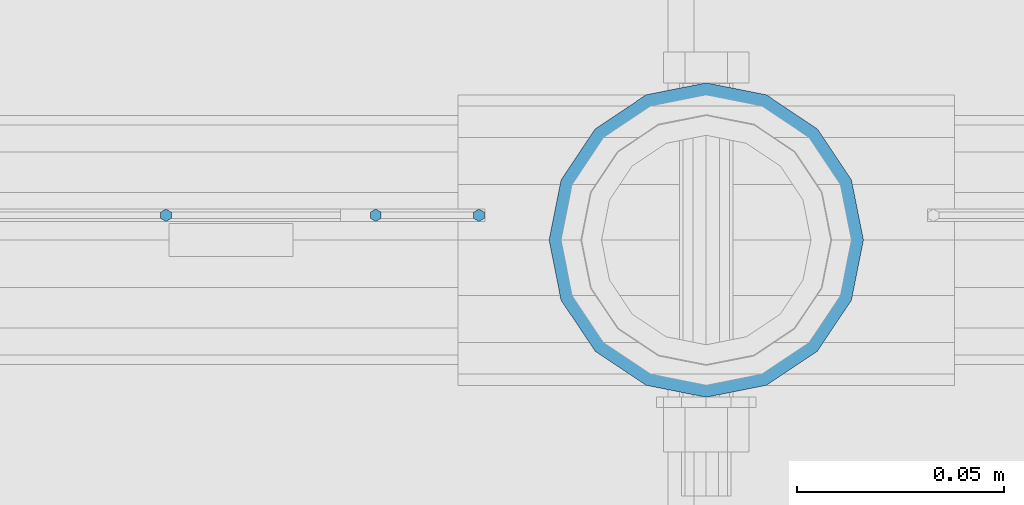
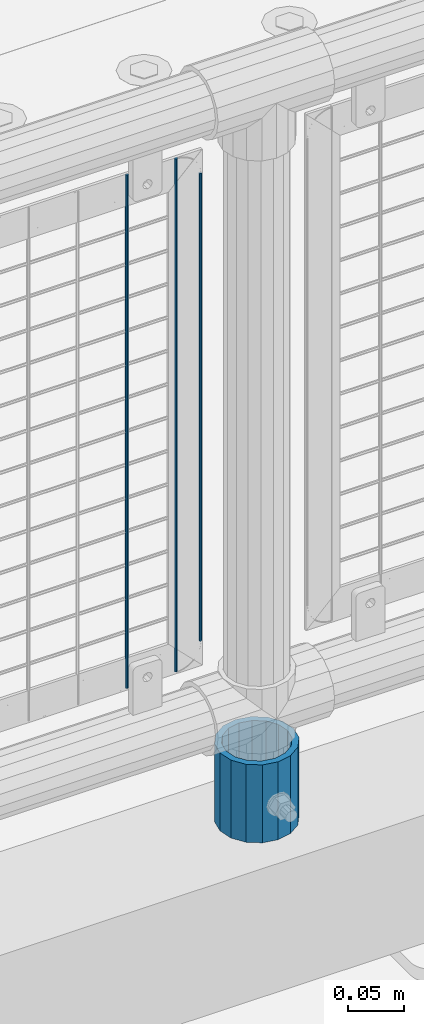
# One storey, part 78 of 242: 4 columns.
"""IFC2X3 building model written with IfcOpenShell, lengths in millimetres."""

from ifc_helpers import new_model, si_unit, frame, origin_with_axes, place, context, subcontext, project, spatial, faceted_brep, material, type_object, element, save


model = new_model("IFC2X3")

# Units and contexts
model_context = context("Model", 3, precision=1e-05, world=origin_with_axes())
body_context = subcontext(model_context, "Body", "Model", "MODEL_VIEW")
ifc_project = project(units=[si_unit("LENGTHUNIT", "METRE", prefix="MILLI"), si_unit("AREAUNIT", "SQUARE_METRE"), si_unit("VOLUMEUNIT", "CUBIC_METRE"), si_unit("MASSUNIT", "GRAM", prefix="KILO"), si_unit("TIMEUNIT", "SECOND"), si_unit("PLANEANGLEUNIT", "RADIAN"), si_unit("SOLIDANGLEUNIT", "STERADIAN"), si_unit("THERMODYNAMICTEMPERATUREUNIT", "DEGREE_CELSIUS"), si_unit("LUMINOUSINTENSITYUNIT", "LUMEN")], contexts=[model_context])

# Site, building, storey
site_placement = place(None, origin_with_axes())
site = spatial("IfcSite", under=ifc_project, at=site_placement, CompositionType="ELEMENT")
building_placement = place(site_placement, origin_with_axes())
building = spatial("IfcBuilding", under=site, at=building_placement, Name="Standard", CompositionType="ELEMENT")
storey_placement = place(building_placement, origin_with_axes())
storey = spatial("IfcBuildingStorey", under=building, at=storey_placement, Name="Undefined", CompositionType="ELEMENT", Elevation=0.0)

# Columns
ifc_material_1 = material(Name="Misc_Undefined")
column_type_1 = type_object("IfcColumnType", Name="D3", PredefinedType="NOTDEFINED")
for number, where, z_axis, x_axis in (
    (1, (-35427.796, -19329.5, 353.02), (-1.0, 0.0, 0.0), (0.0, 0.0, 1.0)),
    (2, (-35377.003, -19329.5, 353.02), (-1.0, 0.0, 0.0), (0.0, 0.0, 1.0)),
):
    element("IfcColumn", number, at=place(storey_placement, frame(where, z_axis=z_axis, x_axis=x_axis)), inside=storey, type_object=column_type_1, material=ifc_material_1, ObjectType="D3", context=body_context, shape_type="Brep", body=[
        faceted_brep([(0.0, -1.50000000000364, 0.0), (-3.63797880709171e-12, -0.750000000003638, -1.29903810567669), (560.0, -0.75, -1.29903810567703), (560.0, -1.5, 0.0), (0.0, 0.749999999996362, -1.29903810567669), (560.0, 0.75, -1.29903810567703), (-3.63797880709171e-12, 1.49999999999636, 0.0), (560.0, 1.5, 0.0), (0.0, 0.749999999996362, 1.29903810567669), (560.0, 0.75, 1.29903810567703), (-3.63797880709171e-12, -0.750000000003638, 1.29903810567669), (560.0, -0.75, 1.29903810567703)], [[[0, 1, 2, 3]], [[1, 4, 5, 2]], [[4, 6, 7, 5]], [[6, 8, 9, 7]], [[8, 10, 11, 9]], [[10, 0, 3, 11]], [[5, 7, 9, 11, 3, 2]], [[10, 8, 6, 4, 1, 0]]]),
    ])
column_1_placement = place(storey_placement, frame((-35352.0, -19329.5, 378.02), z_axis=(-1.0, 0.0, 0.0), x_axis=(0.0, 0.0, 1.0)))
element("IfcColumn", 3, at=column_1_placement, inside=storey, type_object=column_type_1, material=ifc_material_1, ObjectType="D3", context=body_context, shape_type="Brep", body=[
    faceted_brep([(0.0, -1.50000000000364, 0.0), (-3.63797880709171e-12, -0.750000000003638, -1.29903810567669), (510.0, -0.75, -1.29903810567703), (510.0, -1.5, 0.0), (0.0, 0.749999999996362, -1.29903810567669), (510.0, 0.75, -1.29903810567703), (-3.63797880709171e-12, 1.49999999999636, 0.0), (510.0, 1.5, 0.0), (0.0, 0.749999999996362, 1.29903810567669), (510.0, 0.75, 1.29903810567703), (-3.63797880709171e-12, -0.750000000003638, 1.29903810567669), (510.0, -0.75, 1.29903810567703)], [[[0, 1, 2, 3]], [[1, 4, 5, 2]], [[4, 6, 7, 5]], [[6, 8, 9, 7]], [[8, 10, 11, 9]], [[10, 0, 3, 11]], [[5, 7, 9, 11, 3, 2]], [[10, 8, 6, 4, 1, 0]]]),
])
ifc_material_2 = material()
column_type_2 = type_object("IfcColumnType", PredefinedType="NOTDEFINED")
column_2_placement = place(storey_placement, frame((-35297.0, -19335.5, 168.02), z_axis=(0.0, 1.0, 0.0), x_axis=(0.0, 0.0, 1.0)))
element("IfcColumn", 4, at=column_2_placement, inside=storey, type_object=column_type_2, material=ifc_material_2, context=body_context, shape_type="Brep", body=[
    faceted_brep([(0.0, -31.75, 0.0), (0.0, -29.3331751572332, 12.1501989775934), (85.0, -29.3331751572332, 12.1501989775934), (85.0, -31.75, 0.0), (0.0, -22.4506403026717, 22.4506403026717), (85.0, -22.4506403026717, 22.4506403026717), (0.0, -12.1501989775934, 29.3331751572332), (85.0, -12.1501989775934, 29.3331751572332), (0.0, 0.0, 31.75), (85.0, 0.0, 31.75), (0.0, 12.1501989775934, 29.3331751572332), (85.0, 12.1501989775934, 29.3331751572332), (0.0, 22.4506403026717, 22.4506403026717), (85.0, 22.4506403026717, 22.4506403026717), (0.0, 29.3331751572332, 12.1501989775934), (85.0, 29.3331751572332, 12.1501989775934), (0.0, 31.75, 0.0), (85.0, 31.75, 0.0), (0.0, 29.3331751572332, -12.1501989775934), (85.0, 29.3331751572332, -12.1501989775934), (0.0, 22.4506403026717, -22.4506403026717), (85.0, 22.4506403026717, -22.4506403026717), (0.0, 12.1501989775934, -29.3331751572332), (85.0, 12.1501989775934, -29.3331751572332), (0.0, 0.0, -31.75), (85.0, 0.0, -31.75), (0.0, -12.1501989775934, -29.3331751572332), (85.0, -12.1501989775934, -29.3331751572332), (0.0, -22.4506403026717, -22.4506403026717), (85.0, -22.4506403026717, -22.4506403026717), (0.0, -29.3331751572332, -12.1501989775934), (85.0, -29.3331751572332, -12.1501989775934), (0.0, -38.0499999999993, 0.0), (0.0, -35.1536162120537, -14.5611046014928), (85.0, -35.1536162120537, -14.5611046014928), (85.0, -38.0499999999993, 0.0), (0.0, -26.9054130241493, -26.9054130241493), (85.0, -26.9054130241493, -26.9054130241493), (0.0, -14.5611046014928, -35.1536162120537), (85.0, -14.5611046014928, -35.1536162120537), (0.0, 0.0, -38.0499999999993), (85.0, 0.0, -38.0499999999993), (0.0, 14.5611046014928, -35.1536162120537), (85.0, 14.5611046014928, -35.1536162120537), (0.0, 26.9054130241493, -26.9054130241493), (85.0, 26.9054130241493, -26.9054130241493), (0.0, 35.1536162120537, -14.5611046014928), (85.0, 35.1536162120537, -14.5611046014928), (0.0, 38.0499999999993, 0.0), (85.0, 38.0499999999993, 0.0), (0.0, 35.1536162120537, 14.5611046014928), (85.0, 35.1536162120537, 14.5611046014928), (0.0, 26.9054130241493, 26.9054130241493), (85.0, 26.9054130241493, 26.9054130241493), (0.0, 14.5611046014928, 35.1536162120537), (85.0, 14.5611046014928, 35.1536162120537), (0.0, 0.0, 38.0499999999993), (85.0, 0.0, 38.0499999999993), (0.0, -14.5611046014928, 35.1536162120537), (85.0, -14.5611046014928, 35.1536162120537), (0.0, -26.9054130241493, 26.9054130241493), (85.0, -26.9054130241493, 26.9054130241493), (0.0, -35.1536162120537, 14.5611046014928), (85.0, -35.1536162120537, 14.5611046014928)], [[[0, 1, 2, 3]], [[1, 4, 5, 2]], [[4, 6, 7, 5]], [[6, 8, 9, 7]], [[8, 10, 11, 9]], [[10, 12, 13, 11]], [[12, 14, 15, 13]], [[14, 16, 17, 15]], [[16, 18, 19, 17]], [[18, 20, 21, 19]], [[20, 22, 23, 21]], [[22, 24, 25, 23]], [[24, 26, 27, 25]], [[26, 28, 29, 27]], [[28, 30, 31, 29]], [[30, 0, 3, 31]], [[32, 33, 34, 35]], [[33, 36, 37, 34]], [[36, 38, 39, 37]], [[38, 40, 41, 39]], [[40, 42, 43, 41]], [[42, 44, 45, 43]], [[44, 46, 47, 45]], [[46, 48, 49, 47]], [[48, 50, 51, 49]], [[50, 52, 53, 51]], [[52, 54, 55, 53]], [[54, 56, 57, 55]], [[56, 58, 59, 57]], [[58, 60, 61, 59]], [[60, 62, 63, 61]], [[62, 32, 35, 63]], [[37, 39, 41, 43, 45, 47, 49, 51, 53, 55, 57, 59, 61, 63, 35, 34], [5, 7, 9, 11, 13, 15, 17, 19, 21, 23, 25, 27, 29, 31, 3, 2]], [[62, 60, 58, 56, 54, 52, 50, 48, 46, 44, 42, 40, 38, 36, 33, 32], [30, 28, 26, 24, 22, 20, 18, 16, 14, 12, 10, 8, 6, 4, 1, 0]]]),
])

save(model, "model.ifc")
